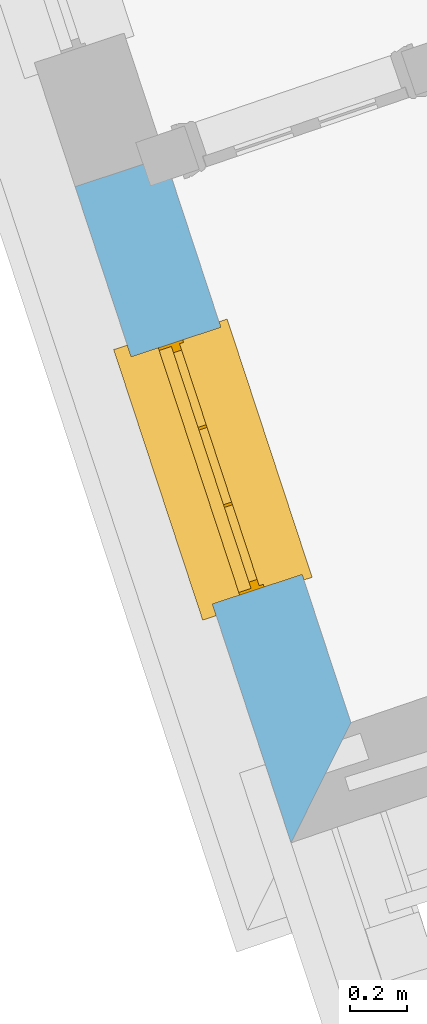
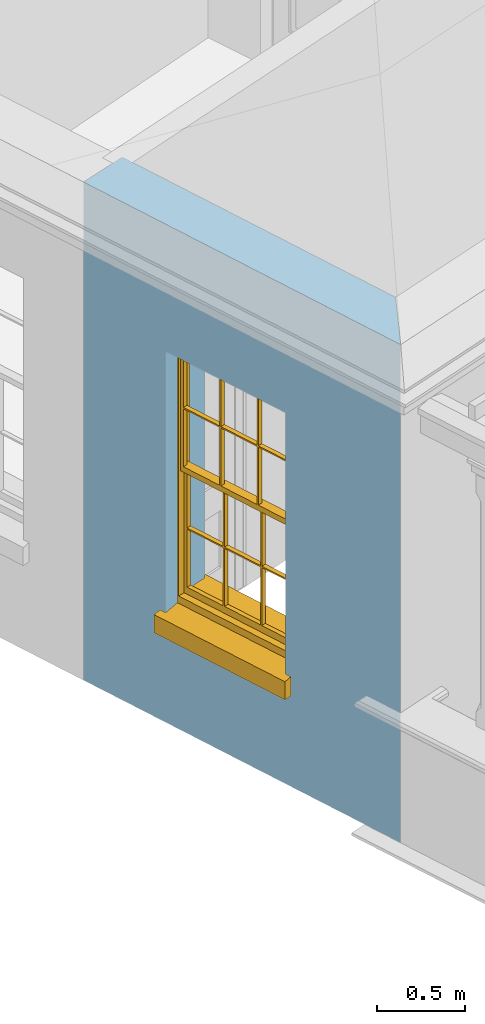
# One storey, part 2 of 10: 1 window, 1 opening, plus 1 element that does not belong to this part.
"""IFC2X3 building model written with IfcOpenShell, lengths in metres."""

import ifcopenshell
import ifcopenshell.guid

model = None  # the IFC model being written
_history = None  # IfcOwnerHistory: only IFC2X3 demands one
_inside = {}  # id of a spatial element -> (the spatial element, [elements in it])
_under = {}  # id of a project, library or spatial element -> (it, [spatial elements below it])
_declared = {}  # id of a project -> (the project, [libraries it declares])
_typed = {}  # id of a type object -> (the type object, [elements of that type])
_made_of = {}  # id of a material, layer set ... -> (it, [elements and type objects made of it])


def new_model(schema):
    """Start an empty IFC model of exactly this schema.

    Asked for "IFC4X3", IfcOpenShell would pick the latest addendum, in which some entities
    have other attributes; the version numbers below select the first issue.
    IFC2X3 requires an IfcOwnerHistory on every rooted entity: one is made here for all.
    """
    global model, _history
    if schema == "IFC4X3":
        model = ifcopenshell.file(schema_version=(4, 3, 0, 0))
    else:
        model = ifcopenshell.file(schema=schema)
    _inside.clear()
    _under.clear()
    _declared.clear()
    _typed.clear()
    _made_of.clear()
    _history = None
    if model.schema == "IFC2X3":
        org = make("IfcOrganization", Name="unknown")
        user = make(
            "IfcPersonAndOrganization",
            ThePerson=make("IfcPerson", FamilyName="unknown"),
            TheOrganization=org,
        )
        app = make(
            "IfcApplication",
            ApplicationDeveloper=org,
            Version="unknown",
            ApplicationFullName="unknown",
            ApplicationIdentifier="unknown",
        )
        _history = make(
            "IfcOwnerHistory",
            OwningUser=user,
            OwningApplication=app,
            ChangeAction="ADDED",
            CreationDate=0,
        )
    return model


def make(cls, **values):
    """One entity of the class cls with the attributes given. An attribute that is None is left unset."""
    return model.create_entity(
        cls, **{name: value for name, value in values.items() if value is not None}
    )


def rooted(cls, **values):
    """An entity with a GlobalId (a new one), such as an element, a storey or a relation."""
    return make(cls, GlobalId=ifcopenshell.guid.new(), OwnerHistory=_history, **values)


def si_unit(unit_type, name, prefix=None):
    """IfcSIUnit, for example si_unit("LENGTHUNIT", "METRE", prefix="MILLI")."""
    return make("IfcSIUnit", UnitType=unit_type, Prefix=prefix, Name=name)


def assignment(units):
    """IfcUnitAssignment: the units of a project."""
    return None if units is None else make("IfcUnitAssignment", Units=units)


def point(xyz):
    """IfcCartesianPoint."""
    return None if xyz is None else make("IfcCartesianPoint", Coordinates=xyz)


def direction(xyz):
    """IfcDirection."""
    return None if xyz is None else make("IfcDirection", DirectionRatios=xyz)


def frame(location, z_axis=None, x_axis=None):
    """IfcAxis2Placement3D, a coordinate frame: its origin and axes. An axis left out is left unset."""
    return make(
        "IfcAxis2Placement3D",
        Location=point(location),
        Axis=direction(z_axis),
        RefDirection=direction(x_axis),
    )


def origin():
    """The frame at (0, 0, 0) with its axes left unset."""
    return frame((0.0, 0.0, 0.0))


def place(relative_to, where):
    """IfcLocalPlacement: puts the frame where relative to a parent placement (None: the world)."""
    return make(
        "IfcLocalPlacement", PlacementRelTo=relative_to, RelativePlacement=where
    )


def context(
    kind, dimensions, precision=None, world=None, true_north=None, identifier=None
):
    """IfcGeometricRepresentationContext, for example the 3D "Model" context."""
    return make(
        "IfcGeometricRepresentationContext",
        ContextIdentifier=identifier,
        ContextType=kind,
        CoordinateSpaceDimension=dimensions,
        Precision=precision,
        WorldCoordinateSystem=world,
        TrueNorth=true_north,
    )


def subcontext(parent, identifier, kind, view, scale=None):
    """IfcGeometricRepresentationSubContext, for example "Body" below "Model"."""
    return make(
        "IfcGeometricRepresentationSubContext",
        ContextIdentifier=identifier,
        ContextType=kind,
        ParentContext=parent,
        TargetScale=scale,
        TargetView=view,
    )


def project(units=None, contexts=None):
    """IfcProject with its units and contexts."""
    return rooted(
        "IfcProject",
        Name="project",
        RepresentationContexts=contexts,
        UnitsInContext=assignment(units),
    )


def spatial(cls, under=None, at=None, **own):
    """A site, building, storey or space (cls), placed at a placement, below another one or the project."""
    s = rooted(cls, ObjectPlacement=at, **own)
    if under is not None:
        _under.setdefault(under.id(), (under, []))[1].append(s)
    return s


def polyline(points):
    """IfcPolyline through the points."""
    return make("IfcPolyline", Points=[point(p) for p in points])


def outline(outer, holes=None, kind="AREA"):
    """IfcArbitraryClosedProfileDef: a profile drawn as a closed curve; with holes, ...WithVoids."""
    if holes is None:
        return make("IfcArbitraryClosedProfileDef", ProfileType=kind, OuterCurve=outer)
    return make(
        "IfcArbitraryProfileDefWithVoids",
        ProfileType=kind,
        OuterCurve=outer,
        InnerCurves=holes,
    )


def extrude(swept, where, along, depth):
    """IfcExtrudedAreaSolid: the profile swept, set in the frame where, extruded along a direction by depth."""
    return make(
        "IfcExtrudedAreaSolid",
        SweptArea=swept,
        Position=where,
        ExtrudedDirection=direction(along),
        Depth=depth,
    )


def faces_of(points, faces, orient=None, outer=None):
    """IfcFace entities. A face is a list of loops; a loop is a list of indices into points, from 0.

    orient and outer hold one flag for each loop. By default every Orientation is true, the
    first loop of a face is its IfcFaceOuterBound and the others are IfcFaceBound.
    """
    made = []
    for i, loops in enumerate(faces):
        bounds = []
        for j, loop in enumerate(loops):
            is_outer = j == 0 if outer is None else outer[i][j]
            bounds.append(
                make(
                    "IfcFaceOuterBound" if is_outer else "IfcFaceBound",
                    Bound=make("IfcPolyLoop", Polygon=[points[k] for k in loop]),
                    Orientation=True if orient is None else orient[i][j],
                )
            )
        made.append(make("IfcFace", Bounds=bounds))
    return made


def faceted_brep(points, faces, orient=None, outer=None, voids=None):
    """IfcFacetedBrep: a solid bounded by flat faces; with voids (closed shells), ...WithVoids."""
    shared = [point(p) for p in points]
    hull = make("IfcClosedShell", CfsFaces=faces_of(shared, faces, orient, outer))
    if voids is None:
        return make("IfcFacetedBrep", Outer=hull)
    return make(
        "IfcFacetedBrepWithVoids",
        Outer=hull,
        Voids=[
            make(cls, CfsFaces=faces_of(shared, fs, o, b)) for cls, fs, o, b in voids
        ],
    )


def shape(context_of_items, identifier, shape_type, items):
    """IfcShapeRepresentation: the items that make up one representation, for example the "Body"."""
    return make(
        "IfcShapeRepresentation",
        ContextOfItems=context_of_items,
        RepresentationIdentifier=identifier,
        RepresentationType=shape_type,
        Items=items,
    )


def material(Name=None, Category=None):
    """IfcMaterial."""
    return make("IfcMaterial", Name=Name, Category=Category)


def layer(
    of_material, thickness, ventilated=None, Name=None, Category=None, Priority=None
):
    """IfcMaterialLayer: one layer of a wall or slab, of a material (None: an air gap)."""
    return make(
        "IfcMaterialLayer",
        Material=of_material,
        LayerThickness=thickness,
        IsVentilated=ventilated,
        Name=Name,
        Category=Category,
        Priority=Priority,
    )


def layer_set(layers, Name=None):
    """IfcMaterialLayerSet."""
    return make("IfcMaterialLayerSet", MaterialLayers=layers, LayerSetName=Name)


def layer_usage(for_layer_set, set_direction, sense, offset, extent=None):
    """IfcMaterialLayerSetUsage: how a layer set lies in its element."""
    return make(
        "IfcMaterialLayerSetUsage",
        ForLayerSet=for_layer_set,
        LayerSetDirection=set_direction,
        DirectionSense=sense,
        OffsetFromReferenceLine=offset,
        ReferenceExtent=extent,
    )


def made_of(thing, what):
    """Note that an element or type object is made of a material, layer set ...; save() writes the relation."""
    if what is not None:
        _made_of.setdefault(what.id(), (what, []))[1].append(thing)
    return thing


def element(
    cls,
    number,
    at=None,
    inside=None,
    cuts=None,
    type_object=None,
    material=None,
    context=None,
    identifier="Body",
    shape_type=None,
    held_by="IfcProductDefinitionShape",
    body=None,
    shapes=None,
    **own,
):
    """One element of the class cls, such as IfcWall. Its Tag is "e" and its number.

    at: its placement. inside: the storey or other place that contains it. cuts: it is an
    opening in that element (IfcRelVoidsElement). A single representation is given by context,
    identifier, shape_type and body (its items); several are given by shapes. held_by: the class
    of the entity that holds the representations. save() writes the other relations.
    """
    e = rooted(cls, Tag="e%d" % number, ObjectPlacement=at, **own)
    if body is not None:
        shapes = [shape(context, identifier, shape_type, body)]
    if shapes is not None:
        e.Representation = make(held_by, Representations=shapes)
    if inside is not None:
        _inside.setdefault(inside.id(), (inside, []))[1].append(e)
    if cuts is not None:
        rooted(
            "IfcRelVoidsElement", RelatingBuildingElement=cuts, RelatedOpeningElement=e
        )
    if type_object is not None:
        _typed.setdefault(type_object.id(), (type_object, []))[1].append(e)
    return made_of(e, material)


def fill(opening, filler):
    """IfcRelFillsElement: the door or window that sits in an opening."""
    return rooted(
        "IfcRelFillsElement",
        RelatingOpeningElement=opening,
        RelatedBuildingElement=filler,
    )


def aggregate(whole, parts):
    """IfcRelAggregates: a whole, such as a stair, and the parts it consists of."""
    return rooted("IfcRelAggregates", RelatingObject=whole, RelatedObjects=parts)


def save(model, path):
    """Write the relations noted so far, then the file.

    IfcRelAggregates (storeys below a building ...), IfcRelContainedInSpatialStructure (elements
    in a storey), IfcRelDefinesByType, IfcRelAssociatesMaterial and IfcRelDeclares: one each for
    every whole, place, type object, material and project.
    """
    for whole, parts in _under.values():
        aggregate(whole, parts)
    for where, things in _inside.values():
        rooted(
            "IfcRelContainedInSpatialStructure",
            RelatedElements=things,
            RelatingStructure=where,
        )
    for kind, things in _typed.values():
        rooted("IfcRelDefinesByType", RelatedObjects=things, RelatingType=kind)
    for what, things in _made_of.values():
        rooted("IfcRelAssociatesMaterial", RelatedObjects=things, RelatingMaterial=what)
    for by, libraries in _declared.values():
        rooted("IfcRelDeclares", RelatingContext=by, RelatedDefinitions=libraries)
    model.write(path)


model = new_model("IFC2X3")

# Units and contexts
model_context = context("Model", 3, world=origin())
body_context = subcontext(model_context, "Body", "Model", "MODEL_VIEW")
ifc_project = project(units=[si_unit("PLANEANGLEUNIT", "RADIAN"), si_unit("MASSUNIT", "GRAM", prefix="KILO"), si_unit("FORCEUNIT", "NEWTON", prefix="KILO"), si_unit("LENGTHUNIT", "METRE")], contexts=[model_context])

# Site, building, storey
site_placement = place(None, origin())
site = spatial("IfcSite", under=ifc_project, at=site_placement, CompositionType="ELEMENT")
building_placement = place(None, origin())
building = spatial("IfcBuilding", under=site, at=building_placement, Name="Building plot-2", CompositionType="ELEMENT")
storey_placement = place(None, frame((0.0, 0.0, 8.2)))
storey = spatial("IfcBuildingStorey", under=building, at=storey_placement, Name="Floor 2", CompositionType="ELEMENT", Elevation=8.2)

# Wall, opening, window
ifc_material = material(Name="Masonry")
ifc_layer = layer(ifc_material, 0.33, ventilated=False)
ifc_layer_set = layer_set([ifc_layer], Name="My Wall")
ifc_layer_usage = layer_usage(ifc_layer_set, "AXIS2", "NEGATIVE", 0.08)
wall_placement = place(storey_placement, origin())
wall = element("IfcWallStandardCase", 1, at=wall_placement, inside=storey, material=ifc_layer_usage, Name="exterior", context=body_context, shape_type="SweptSolid", body=[
    extrude(outline(polyline([(28.7663601729081, 33.4013868683963), (28.4528876869268, 33.2982607294562), (29.2071844062656, 31.0054252736847), (29.4163238863492, 31.425692411646), (28.7663601729081, 33.4013868683963)])), origin(), (0.0, 0.0, 1.0), 3.45),
])
opening_placement = place(storey_placement, frame((0.0, 0.0, 0.75)))
opening = element("IfcOpeningElement", 2, at=opening_placement, cuts=wall, Name="Opening", ObjectType="Opening", context=body_context, shape_type="SweptSolid", body=[
    extrude(outline(polyline([(28.6483268982478, 32.7041842318709), (28.9327050389614, 31.8397601038618), (29.2461775249427, 31.9428862428019), (28.9617993842291, 32.807310370811), (28.6483268982478, 32.7041842318709)])), origin(), (0.0, 0.0, 1.0), 1.82),
])
window_placement = place(storey_placement, frame((28.8858060542942, 32.7823100947043, 0.75), z_axis=(0.0, 0.0, 1.0), x_axis=(0.284378140713624, -0.864424128009084, 0.0)))
window = element("IfcWindow", 3, at=window_placement, inside=storey, Name="circulation outside window", OverallHeight=1.82, OverallWidth=0.91, context=body_context, shape_type="Brep", held_by="IfcProductRepresentation", body=[
    faceted_brep([(0.033125, -0.105, 0.975209), (0.01, -0.105, 0.975209), (0.033125, -0.105, 1.376042), (0.876875, -0.105, 0.975209), (0.876875, -0.105, 1.376042), (0.9, -0.105, 0.975209), (0.876875, -0.105, 1.386042), (0.876875, -0.105, 1.786875), (0.9, -0.105, 1.81), (0.033125, -0.105, 1.786875), (0.033125, -0.105, 1.386042), (0.01, -0.105, 1.81), (0.876875, -0.135, 1.376042), (0.876875, -0.135, 0.975209), (0.9, -0.135, 0.937083), (0.033125, -0.135, 1.786875), (0.01, -0.135, 1.81), (0.033125, -0.135, 1.386042), (0.01, -0.135, 0.937083), (0.033125, -0.135, 0.975209), (0.033125, -0.135, 1.376042), (0.876875, -0.135, 1.786875), (0.876875, -0.135, 1.386042), (0.9, -0.135, 1.81), (0.033125, -0.105, 0.937083), (0.01, -0.105, 0.937083), (0.033125, -0.105, 0.53625), (0.876875, -0.105, 0.937083), (0.876875, -0.105, 0.53625), (0.9, -0.105, 0.937083), (0.876875, -0.105, 0.52625), (0.876875, -0.105, 0.125417), (0.9, -0.105, 0.077167), (0.033125, -0.105, 0.125417), (0.033125, -0.105, 0.52625), (0.01, -0.105, 0.077167), (-0.0425, -0.25, 0.01), (-0.0425, -0.3, 0.001667), (0.0, -0.25, 0.01), (0.9525, -0.25, 0.01), (0.91, -0.25, 0.01), (0.9525, -0.3, 0.001667), (-0.02, 0.08, 0.077167), (0.0, 0.08, 0.077167), (-0.02, 0.11, 0.077167), (0.0, -0.06, 0.077167), (0.01, -0.06, 0.077167), (0.91, -0.06, 0.077167), (0.91, 0.08, 0.077167), (0.9, -0.06, 0.077167), (0.93, 0.08, 0.077167), (0.93, 0.11, 0.077167), (0.01, -0.075, 0.975209), (0.9, -0.075, 0.975209), (0.876875, -0.075, 0.125417), (0.876875, -0.075, 0.52625), (0.9, -0.075, 0.077167), (0.876875, -0.075, 0.53625), (0.876875, -0.075, 0.937083), (0.033125, -0.075, 0.125417), (0.01, -0.075, 0.077167), (0.033125, -0.075, 0.52625), (0.033125, -0.075, 0.937083), (0.033125, -0.075, 0.53625), (-0.02, 0.08, 0.052167), (-0.02, 0.11, 0.052167), (0.93, 0.11, 0.052167), (0.93, 0.08, 0.052167), (0.91, 0.08, 0.052167), (0.0, 0.08, 0.052167), (0.91, -0.15, 0.026667), (0.0, -0.15, 0.026667), (-0.0425, -0.3, -0.123333), (0.9525, -0.3, -0.123333), (-0.0425, -0.25, -0.123333), (0.9525, -0.25, -0.123333), (0.01, -0.06, 1.81), (0.9, -0.06, 1.81), (0.0, -0.06, 1.82), (0.91, -0.06, 1.82), (0.01, -0.15, 0.077167), (0.9, -0.15, 0.077167), (0.592292, -0.105, 0.125417), (0.592292, -0.075, 0.125417), (0.317708, -0.075, 0.125417), (0.317708, -0.105, 0.125417), (0.592292, -0.105, 0.53625), (0.317708, -0.105, 0.53625), (0.317708, -0.105, 0.52625), (0.592292, -0.105, 0.52625), (0.592292, -0.075, 0.53625), (0.317708, -0.075, 0.53625), (0.592292, -0.135, 1.386042), (0.592292, -0.105, 1.386042), (0.317708, -0.105, 1.386042), (0.317708, -0.135, 1.386042), (0.317708, -0.135, 1.376042), (0.592292, -0.135, 1.376042), (0.317708, -0.105, 1.376042), (0.592292, -0.105, 1.376042), (0.602292, -0.135, 1.376042), (0.592292, -0.135, 0.975209), (0.602292, -0.135, 0.975209), (0.602292, -0.105, 0.975209), (0.592292, -0.105, 0.975209), (0.602292, -0.105, 1.376042), (0.602292, -0.075, 0.53625), (0.602292, -0.105, 0.53625), (0.317708, -0.075, 0.52625), (0.307708, -0.075, 0.125417), (0.307708, -0.075, 0.52625), (0.602292, -0.075, 0.52625), (0.602292, -0.075, 0.125417), (0.592292, -0.075, 0.52625), (0.307708, -0.075, 0.53625), (0.317708, -0.075, 0.937083), (0.307708, -0.075, 0.937083), (0.602292, -0.075, 0.937083), (0.592292, -0.075, 0.937083), (0.307708, -0.105, 0.52625), (0.307708, -0.105, 0.125417), (0.307708, -0.105, 0.53625), (0.307708, -0.105, 0.937083), (0.592292, -0.105, 0.937083), (0.317708, -0.105, 0.937083), (0.602292, -0.105, 0.937083), (0.602292, -0.105, 0.52625), (0.602292, -0.105, 0.125417), (0.307708, -0.135, 1.386042), (0.307708, -0.135, 1.376042), (0.307708, -0.135, 0.975209), (0.317708, -0.135, 0.975209), (0.317708, -0.135, 1.786875), (0.307708, -0.135, 1.786875), (0.602292, -0.135, 1.786875), (0.592292, -0.135, 1.786875), (0.602292, -0.135, 1.386042), (0.602292, -0.105, 1.386042), (0.307708, -0.105, 1.386042), (0.307708, -0.105, 1.786875), (0.317708, -0.105, 1.786875), (0.592292, -0.105, 1.786875), (0.602292, -0.105, 1.786875), (0.307708, -0.105, 1.376042), (0.317708, -0.105, 0.975209), (0.307708, -0.105, 0.975209), (0.91, -0.15, 1.82), (0.9, -0.15, 1.81), (0.01, -0.15, 1.81), (0.0, -0.15, 1.82), (0.91, -0.25, 0.0), (0.0, -0.25, 0.0), (0.91, 0.08, 0.0), (0.0, 0.08, 0.0)], [[[0, 1, 2]], [[3, 4, 5]], [[6, 7, 8]], [[9, 10, 11]], [[12, 13, 14]], [[15, 16, 17]], [[18, 19, 20]], [[21, 22, 23]], [[24, 25, 26]], [[27, 28, 29]], [[30, 31, 32]], [[33, 34, 35]], [[14, 27, 29]], [[25, 24, 18]], [[36, 37, 38]], [[39, 40, 41]], [[42, 43, 44]], [[45, 46, 43]], [[47, 48, 49]], [[50, 51, 48]], [[1, 0, 52]], [[5, 53, 3]], [[54, 55, 56]], [[57, 58, 53]], [[59, 60, 61]], [[62, 63, 52]], [[48, 43, 46, 49]], [[51, 44, 43, 48]], [[64, 42, 44, 65]], [[65, 44, 51, 66]], [[66, 51, 50, 67]], [[65, 66, 68, 69]], [[60, 56, 49, 46]], [[70, 71, 38, 40]], [[37, 41, 40, 38]], [[37, 72, 73, 41]], [[74, 75, 73, 72]], [[8, 11, 76, 77]], [[76, 78, 79, 77]], [[32, 35, 80, 81]], [[81, 80, 71, 70]], [[82, 83, 84, 85]], [[86, 87, 88, 89]], [[86, 90, 91, 87]], [[92, 93, 94, 95]], [[92, 95, 96, 97]], [[96, 98, 99, 97]], [[100, 97, 101, 102]], [[103, 104, 99, 105]], [[97, 99, 104, 101]], [[102, 103, 105, 100]], [[28, 57, 106, 107]], [[108, 84, 109, 110]], [[111, 112, 83, 113]], [[114, 110, 61, 63]], [[90, 113, 108, 91]], [[115, 91, 114, 116]], [[117, 106, 90, 118]], [[111, 106, 57, 55]], [[119, 110, 109, 120]], [[34, 61, 110, 119]], [[89, 113, 83, 82]], [[88, 108, 113, 89]], [[85, 84, 108, 88]], [[121, 114, 63, 26]], [[122, 116, 114, 121]], [[123, 118, 90, 86]], [[87, 91, 115, 124]], [[107, 106, 117, 125]], [[126, 111, 55, 30]], [[127, 112, 111, 126]], [[126, 30, 28, 107]], [[88, 119, 120, 85]], [[126, 89, 82, 127]], [[125, 123, 86, 107]], [[121, 26, 34, 119]], [[124, 122, 121, 87]], [[128, 17, 20, 129]], [[96, 129, 130, 131]], [[132, 133, 128, 95]], [[134, 135, 92, 136]], [[100, 12, 22, 136]], [[137, 6, 4, 105]], [[94, 138, 139, 140]], [[137, 93, 141, 142]], [[99, 98, 94, 93]], [[143, 2, 10, 138]], [[144, 145, 143, 98]], [[129, 143, 145, 130]], [[20, 2, 143, 129]], [[131, 144, 98, 96]], [[128, 138, 10, 17]], [[133, 139, 138, 128]], [[135, 141, 93, 92]], [[95, 94, 140, 132]], [[22, 6, 137, 136]], [[136, 137, 142, 134]], [[100, 105, 4, 12]], [[107, 86, 89, 126]], [[106, 111, 113, 90]], [[91, 108, 110, 114]], [[87, 121, 119, 88]], [[97, 100, 136, 92]], [[129, 96, 95, 128]], [[98, 143, 138, 94]], [[105, 99, 93, 137]], [[131, 101, 104, 144]], [[124, 115, 118, 123]], [[132, 140, 141, 135]], [[120, 109, 59, 33]], [[15, 9, 139, 133]], [[134, 142, 7, 21]], [[31, 54, 112, 127]], [[36, 74, 72, 37]], [[39, 41, 73, 75]], [[18, 14, 101, 131]], [[23, 16, 132, 135]], [[83, 56, 60, 84]], [[52, 53, 118, 115]], [[53, 52, 144, 104]], [[11, 8, 141, 140]], [[14, 18, 124, 123]], [[2, 1, 11, 10]], [[8, 5, 4, 6]], [[57, 53, 56, 55]], [[60, 52, 63, 61]], [[26, 25, 35, 34]], [[32, 29, 28, 30]], [[14, 23, 22, 12]], [[18, 20, 17, 16]], [[19, 0, 2, 20]], [[17, 10, 9, 15]], [[12, 4, 3, 13]], [[21, 7, 6, 22]], [[27, 58, 57, 28]], [[30, 55, 54, 31]], [[33, 59, 61, 34]], [[26, 63, 62, 24]], [[5, 8, 77, 53]], [[76, 11, 1, 52]], [[46, 45, 78, 76]], [[49, 77, 79, 47]], [[70, 146, 147, 81]], [[71, 80, 148, 149]], [[19, 130, 145, 0]], [[102, 13, 3, 103]], [[116, 122, 24, 62]], [[29, 32, 81, 14]], [[80, 35, 25, 18]], [[60, 46, 76, 52]], [[77, 49, 56, 53]], [[23, 14, 81, 147]], [[16, 148, 80, 18]], [[35, 85, 120]], [[120, 33, 35]], [[127, 82, 32]], [[32, 31, 127]], [[32, 82, 85, 35]], [[102, 101, 14]], [[14, 13, 102]], [[18, 131, 130]], [[130, 19, 18]], [[134, 21, 23]], [[23, 135, 134]], [[16, 15, 133]], [[133, 132, 16]], [[11, 140, 139]], [[139, 9, 11]], [[142, 141, 8]], [[8, 7, 142]], [[23, 147, 148, 16]], [[146, 149, 148, 147]], [[52, 115, 116]], [[116, 62, 52]], [[118, 53, 117]], [[58, 117, 53]], [[27, 125, 117, 58]], [[56, 83, 112]], [[112, 54, 56]], [[109, 84, 60]], [[60, 59, 109]], [[125, 27, 14]], [[14, 123, 125]], [[122, 124, 18]], [[18, 24, 122]], [[145, 144, 52]], [[52, 0, 145]], [[103, 3, 53]], [[53, 104, 103]], [[79, 78, 149, 146]], [[78, 45, 71, 149]], [[146, 70, 47, 79]], [[150, 75, 74, 151]], [[68, 66, 67]], [[48, 68, 67, 50]], [[69, 64, 65]], [[42, 64, 69, 43]], [[69, 68, 152, 153]], [[70, 68, 48, 47]], [[150, 152, 68, 70]], [[43, 69, 71, 45]], [[69, 153, 151, 71]], [[152, 150, 151, 153]], [[38, 151, 74, 36]], [[71, 151, 38]], [[39, 75, 150, 40]], [[40, 150, 70]]]),
])
fill(opening, window)

save(model, "model.ifc")
